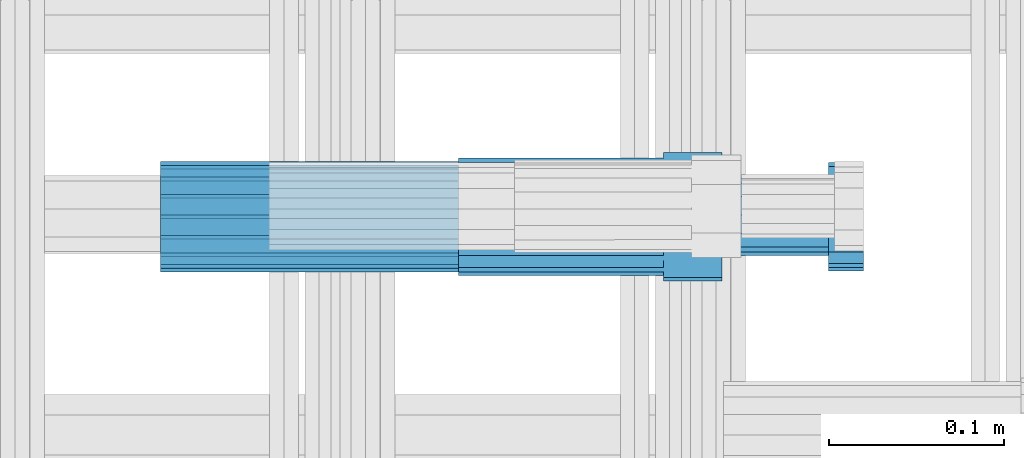
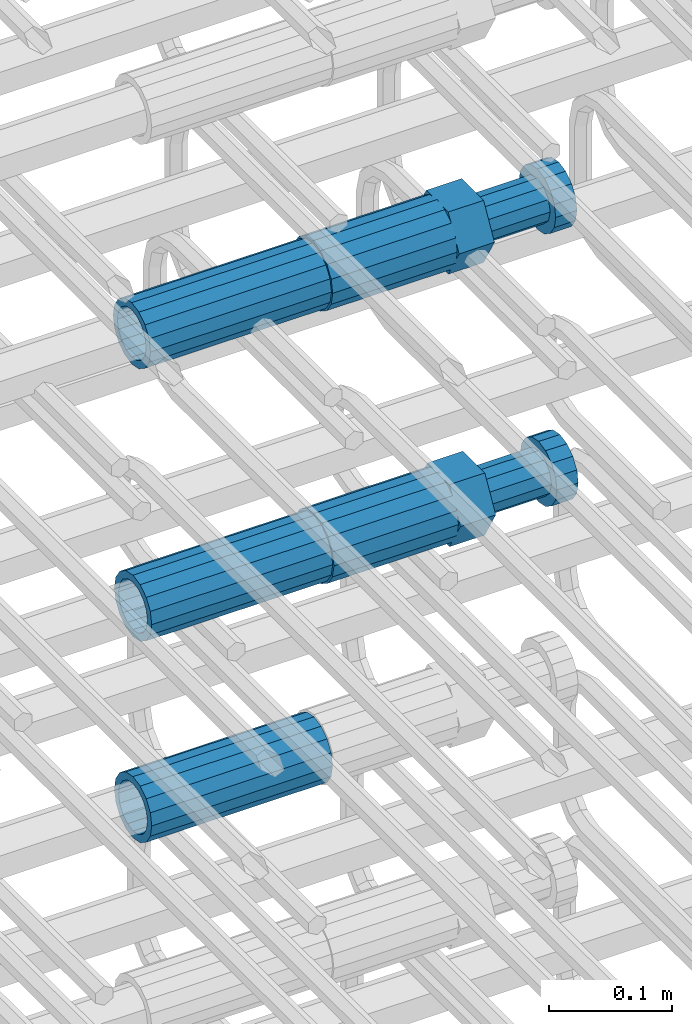
# One storey, part 47 of 177: 5 beams.
"""IFC2X3 building model written with IfcOpenShell, lengths in millimetres."""

from ifc_helpers import new_model, si_unit, frame, origin_with_axes, place, context, subcontext, project, spatial, faceted_brep, material, type_object, element, save


model = new_model("IFC2X3")

# Units and contexts
model_context_1 = context("Model", 3, precision=1e-05, world=origin_with_axes())
model_context_2 = context("Model", 3, precision=1e-05, world=origin_with_axes())
body_context = subcontext(model_context_2, "Body", "Model", "MODEL_VIEW")
ifc_project = project(units=[si_unit("LENGTHUNIT", "METRE", prefix="MILLI"), si_unit("AREAUNIT", "SQUARE_METRE"), si_unit("VOLUMEUNIT", "CUBIC_METRE"), si_unit("MASSUNIT", "GRAM", prefix="KILO"), si_unit("TIMEUNIT", "SECOND"), si_unit("PLANEANGLEUNIT", "RADIAN"), si_unit("SOLIDANGLEUNIT", "STERADIAN"), si_unit("THERMODYNAMICTEMPERATUREUNIT", "DEGREE_CELSIUS"), si_unit("LUMINOUSINTENSITYUNIT", "LUMEN")], contexts=[model_context_1])

# Site, building, storey
site_placement = place(None, origin_with_axes())
site = spatial("IfcSite", under=ifc_project, at=site_placement, CompositionType="ELEMENT")
building_placement = place(site_placement, origin_with_axes())
building = spatial("IfcBuilding", under=site, at=building_placement, Name="Undefined", CompositionType="ELEMENT")
storey_placement = place(building_placement, origin_with_axes())
storey = spatial("IfcBuildingStorey", under=building, at=storey_placement, Name="Undefined", CompositionType="ELEMENT", Elevation=0.0)

# Beams
ifc_material = material(Name="STEEL/S275")
beam_type_1 = type_object("IfcBeamType", PredefinedType="NOTDEFINED")
beam_1_placement = place(storey_placement, frame((2030819.00847313, 6206284.98588033, 21025.9891664316), z_axis=(0.0, 0.0, -1.0), x_axis=(1.0, 0.0, 0.0)))
element("IfcBeam", 1, at=beam_1_placement, inside=storey, type_object=beam_type_1, material=ifc_material, Name="AG40N", context=body_context, shape_type="Brep", body=[
    faceted_brep([(0.0, -23.5000000001164, -9.31322574615479e-10), (0.0, -21.7111690140155, 8.99306066054851), (170.0, -21.7111690140155, 8.99306066054851), (170.0, -23.5, 0.0), (0.0, -16.6170093578839, 16.6170093575493), (170.0, -16.6170093578839, 16.6170093575493), (0.0, -8.99306066057943, 21.7111690137535), (170.0, -8.99306066057943, 21.7111690137535), (0.0, 1.16415321826935e-10, 23.5), (170.0, 0.0, 23.5), (0.0, 8.99306066057943, 21.7111690137535), (170.0, 8.99306066057943, 21.7111690137535), (0.0, 16.6170093578839, 16.6170093575493), (170.0, 16.6170093578839, 16.6170093575493), (0.0, 21.7111690140155, 8.99306066054851), (170.0, 21.7111690140155, 8.99306066054851), (0.0, 23.5000000001164, -9.31322574615479e-10), (170.0, 23.5, 0.0), (0.0, 21.7111690140155, -8.99306066054851), (170.0, 21.7111690140155, -8.99306066054851), (0.0, 16.6170093578839, -16.6170093575493), (170.0, 16.6170093578839, -16.6170093575493), (0.0, 8.99306066057943, -21.7111690137535), (170.0, 8.99306066057943, -21.7111690137535), (0.0, 1.16415321826935e-10, -23.5000000009313), (170.0, 0.0, -23.5), (0.0, -8.99306066057943, -21.7111690137535), (170.0, -8.99306066057943, -21.7111690137535), (0.0, -16.6170093578839, -16.6170093575493), (170.0, -16.6170093578839, -16.6170093575493), (0.0, -21.7111690140155, -8.99306066054851), (170.0, -21.7111690140155, -8.99306066054851), (0.0, -30.5, 0.0), (0.0, -28.1783257415937, -11.6718446873128), (170.0, -28.1783257415937, -11.6718446873128), (170.0, -30.5, 0.0), (0.0, -21.5667568261888, -21.5667568258941), (170.0, -21.5667568261888, -21.5667568258941), (0.0, -11.6718446871346, -28.1783257415518), (170.0, -11.6718446871346, -28.1783257415518), (0.0, 0.0, -30.5), (170.0, 0.0, -30.5), (0.0, 11.6718446871346, -28.1783257415518), (170.0, 11.6718446871346, -28.1783257415518), (0.0, 21.5667568261888, -21.5667568258941), (170.0, 21.5667568261888, -21.5667568258941), (0.0, 28.1783257415937, -11.6718446873128), (170.0, 28.1783257415937, -11.6718446873128), (0.0, 30.5, 0.0), (170.0, 30.5, 0.0), (0.0, 28.1783257415937, 11.6718446873128), (170.0, 28.1783257415937, 11.6718446873128), (0.0, 21.5667568261888, 21.5667568258941), (170.0, 21.5667568261888, 21.5667568258941), (0.0, 11.6718446871346, 28.1783257415518), (170.0, 11.6718446871346, 28.1783257415518), (0.0, 0.0, 30.5), (170.0, 0.0, 30.5), (0.0, -11.6718446871346, 28.1783257415518), (170.0, -11.6718446871346, 28.1783257415518), (0.0, -21.5667568261888, 21.5667568258941), (170.0, -21.5667568261888, 21.5667568258941), (0.0, -28.1783257415937, 11.6718446873128), (170.0, -28.1783257415937, 11.6718446873128)], [[[0, 1, 2, 3]], [[1, 4, 5, 2]], [[4, 6, 7, 5]], [[6, 8, 9, 7]], [[8, 10, 11, 9]], [[10, 12, 13, 11]], [[12, 14, 15, 13]], [[14, 16, 17, 15]], [[16, 18, 19, 17]], [[18, 20, 21, 19]], [[20, 22, 23, 21]], [[22, 24, 25, 23]], [[24, 26, 27, 25]], [[26, 28, 29, 27]], [[28, 30, 31, 29]], [[30, 0, 3, 31]], [[32, 33, 34, 35]], [[33, 36, 37, 34]], [[36, 38, 39, 37]], [[38, 40, 41, 39]], [[40, 42, 43, 41]], [[42, 44, 45, 43]], [[44, 46, 47, 45]], [[46, 48, 49, 47]], [[48, 50, 51, 49]], [[50, 52, 53, 51]], [[52, 54, 55, 53]], [[54, 56, 57, 55]], [[56, 58, 59, 57]], [[58, 60, 61, 59]], [[60, 62, 63, 61]], [[62, 32, 35, 63]], [[37, 39, 41, 43, 45, 47, 49, 51, 53, 55, 57, 59, 61, 63, 35, 34], [5, 7, 9, 11, 13, 15, 17, 19, 21, 23, 25, 27, 29, 31, 3, 2]], [[62, 60, 58, 56, 54, 52, 50, 48, 46, 44, 42, 40, 38, 36, 33, 32], [30, 28, 26, 24, 22, 20, 18, 16, 14, 12, 10, 8, 6, 4, 1, 0]]]),
])
beam_2_placement = place(storey_placement, frame((2030819.00847313, 6206282.98588033, 20756.4868004557), z_axis=(0.0, 0.0, -1.0), x_axis=(1.0, 0.0, 0.0)))
element("IfcBeam", 2, at=beam_2_placement, inside=storey, type_object=beam_type_1, material=ifc_material, Name="AG40N", context=body_context, shape_type="Brep", body=[
    faceted_brep([(0.0, -23.5000000001164, -9.31322574615479e-10), (0.0, -21.7111690140155, 8.99306066054851), (170.0, -21.7111690140155, 8.99306066054851), (170.0, -23.5, 0.0), (0.0, -16.6170093578839, 16.6170093575493), (170.0, -16.6170093578839, 16.6170093575493), (0.0, -8.99306066057943, 21.7111690137535), (170.0, -8.99306066057943, 21.7111690137535), (0.0, 1.16415321826935e-10, 23.5), (170.0, 0.0, 23.5), (0.0, 8.99306066057943, 21.7111690137535), (170.0, 8.99306066057943, 21.7111690137535), (0.0, 16.6170093578839, 16.6170093575493), (170.0, 16.6170093578839, 16.6170093575493), (0.0, 21.7111690140155, 8.99306066054851), (170.0, 21.7111690140155, 8.99306066054851), (0.0, 23.5000000001164, -9.31322574615479e-10), (170.0, 23.5, 0.0), (0.0, 21.7111690140155, -8.99306066054851), (170.0, 21.7111690140155, -8.99306066054851), (0.0, 16.6170093578839, -16.6170093575493), (170.0, 16.6170093578839, -16.6170093575493), (0.0, 8.99306066057943, -21.7111690137535), (170.0, 8.99306066057943, -21.7111690137535), (0.0, 1.16415321826935e-10, -23.5000000009313), (170.0, 0.0, -23.5), (0.0, -8.99306066057943, -21.7111690137535), (170.0, -8.99306066057943, -21.7111690137535), (0.0, -16.6170093578839, -16.6170093575493), (170.0, -16.6170093578839, -16.6170093575493), (0.0, -21.7111690140155, -8.99306066054851), (170.0, -21.7111690140155, -8.99306066054851), (0.0, -30.5, 0.0), (0.0, -28.1783257415937, -11.6718446873128), (170.0, -28.1783257415937, -11.6718446873128), (170.0, -30.5, 0.0), (0.0, -21.5667568261888, -21.5667568258941), (170.0, -21.5667568261888, -21.5667568258941), (0.0, -11.6718446871346, -28.1783257415518), (170.0, -11.6718446871346, -28.1783257415518), (0.0, 0.0, -30.5), (170.0, 0.0, -30.5), (0.0, 11.6718446871346, -28.1783257415518), (170.0, 11.6718446871346, -28.1783257415518), (0.0, 21.5667568261888, -21.5667568258941), (170.0, 21.5667568261888, -21.5667568258941), (0.0, 28.1783257415937, -11.6718446873128), (170.0, 28.1783257415937, -11.6718446873128), (0.0, 30.5, 0.0), (170.0, 30.5, 0.0), (0.0, 28.1783257415937, 11.6718446873128), (170.0, 28.1783257415937, 11.6718446873128), (0.0, 21.5667568261888, 21.5667568258941), (170.0, 21.5667568261888, 21.5667568258941), (0.0, 11.6718446871346, 28.1783257415518), (170.0, 11.6718446871346, 28.1783257415518), (0.0, 0.0, 30.5), (170.0, 0.0, 30.5), (0.0, -11.6718446871346, 28.1783257415518), (170.0, -11.6718446871346, 28.1783257415518), (0.0, -21.5667568261888, 21.5667568258941), (170.0, -21.5667568261888, 21.5667568258941), (0.0, -28.1783257415937, 11.6718446873128), (170.0, -28.1783257415937, 11.6718446873128)], [[[0, 1, 2, 3]], [[1, 4, 5, 2]], [[4, 6, 7, 5]], [[6, 8, 9, 7]], [[8, 10, 11, 9]], [[10, 12, 13, 11]], [[12, 14, 15, 13]], [[14, 16, 17, 15]], [[16, 18, 19, 17]], [[18, 20, 21, 19]], [[20, 22, 23, 21]], [[22, 24, 25, 23]], [[24, 26, 27, 25]], [[26, 28, 29, 27]], [[28, 30, 31, 29]], [[30, 0, 3, 31]], [[32, 33, 34, 35]], [[33, 36, 37, 34]], [[36, 38, 39, 37]], [[38, 40, 41, 39]], [[40, 42, 43, 41]], [[42, 44, 45, 43]], [[44, 46, 47, 45]], [[46, 48, 49, 47]], [[48, 50, 51, 49]], [[50, 52, 53, 51]], [[52, 54, 55, 53]], [[54, 56, 57, 55]], [[56, 58, 59, 57]], [[58, 60, 61, 59]], [[60, 62, 63, 61]], [[62, 32, 35, 63]], [[37, 39, 41, 43, 45, 47, 49, 51, 53, 55, 57, 59, 61, 63, 35, 34], [5, 7, 9, 11, 13, 15, 17, 19, 21, 23, 25, 27, 29, 31, 3, 2]], [[62, 60, 58, 56, 54, 52, 50, 48, 46, 44, 42, 40, 38, 36, 33, 32], [30, 28, 26, 24, 22, 20, 18, 16, 14, 12, 10, 8, 6, 4, 1, 0]]]),
])
beam_3_placement = place(storey_placement, frame((2030819.00847313, 6206282.98588033, 20556.4868004557), z_axis=(0.0, 0.0, -1.0), x_axis=(1.0, 0.0, 0.0)))
element("IfcBeam", 3, at=beam_3_placement, inside=storey, type_object=beam_type_1, material=ifc_material, Name="AG40N", context=body_context, shape_type="Brep", body=[
    faceted_brep([(0.0, -23.5000000001164, -9.31322574615479e-10), (0.0, -21.7111690140155, 8.99306066054851), (170.0, -21.7111690140155, 8.99306066054851), (170.0, -23.5, 0.0), (0.0, -16.6170093578839, 16.6170093575493), (170.0, -16.6170093578839, 16.6170093575493), (0.0, -8.99306066057943, 21.7111690137535), (170.0, -8.99306066057943, 21.7111690137535), (0.0, 1.16415321826935e-10, 23.5), (170.0, 0.0, 23.5), (0.0, 8.99306066057943, 21.7111690137535), (170.0, 8.99306066057943, 21.7111690137535), (0.0, 16.6170093578839, 16.6170093575493), (170.0, 16.6170093578839, 16.6170093575493), (0.0, 21.7111690140155, 8.99306066054851), (170.0, 21.7111690140155, 8.99306066054851), (0.0, 23.5000000001164, -9.31322574615479e-10), (170.0, 23.5, 0.0), (0.0, 21.7111690140155, -8.99306066054851), (170.0, 21.7111690140155, -8.99306066054851), (0.0, 16.6170093578839, -16.6170093575493), (170.0, 16.6170093578839, -16.6170093575493), (0.0, 8.99306066057943, -21.7111690137535), (170.0, 8.99306066057943, -21.7111690137535), (0.0, 1.16415321826935e-10, -23.5000000009313), (170.0, 0.0, -23.5), (0.0, -8.99306066057943, -21.7111690137535), (170.0, -8.99306066057943, -21.7111690137535), (0.0, -16.6170093578839, -16.6170093575493), (170.0, -16.6170093578839, -16.6170093575493), (0.0, -21.7111690140155, -8.99306066054851), (170.0, -21.7111690140155, -8.99306066054851), (0.0, -30.5, 0.0), (0.0, -28.1783257415937, -11.6718446873128), (170.0, -28.1783257415937, -11.6718446873128), (170.0, -30.5, 0.0), (0.0, -21.5667568261888, -21.5667568258941), (170.0, -21.5667568261888, -21.5667568258941), (0.0, -11.6718446871346, -28.1783257415518), (170.0, -11.6718446871346, -28.1783257415518), (0.0, 0.0, -30.5), (170.0, 0.0, -30.5), (0.0, 11.6718446871346, -28.1783257415518), (170.0, 11.6718446871346, -28.1783257415518), (0.0, 21.5667568261888, -21.5667568258941), (170.0, 21.5667568261888, -21.5667568258941), (0.0, 28.1783257415937, -11.6718446873128), (170.0, 28.1783257415937, -11.6718446873128), (0.0, 30.5, 0.0), (170.0, 30.5, 0.0), (0.0, 28.1783257415937, 11.6718446873128), (170.0, 28.1783257415937, 11.6718446873128), (0.0, 21.5667568261888, 21.5667568258941), (170.0, 21.5667568261888, 21.5667568258941), (0.0, 11.6718446871346, 28.1783257415518), (170.0, 11.6718446871346, 28.1783257415518), (0.0, 0.0, 30.5), (170.0, 0.0, 30.5), (0.0, -11.6718446871346, 28.1783257415518), (170.0, -11.6718446871346, 28.1783257415518), (0.0, -21.5667568261888, 21.5667568258941), (170.0, -21.5667568261888, 21.5667568258941), (0.0, -28.1783257415937, 11.6718446873128), (170.0, -28.1783257415937, 11.6718446873128)], [[[0, 1, 2, 3]], [[1, 4, 5, 2]], [[4, 6, 7, 5]], [[6, 8, 9, 7]], [[8, 10, 11, 9]], [[10, 12, 13, 11]], [[12, 14, 15, 13]], [[14, 16, 17, 15]], [[16, 18, 19, 17]], [[18, 20, 21, 19]], [[20, 22, 23, 21]], [[22, 24, 25, 23]], [[24, 26, 27, 25]], [[26, 28, 29, 27]], [[28, 30, 31, 29]], [[30, 0, 3, 31]], [[32, 33, 34, 35]], [[33, 36, 37, 34]], [[36, 38, 39, 37]], [[38, 40, 41, 39]], [[40, 42, 43, 41]], [[42, 44, 45, 43]], [[44, 46, 47, 45]], [[46, 48, 49, 47]], [[48, 50, 51, 49]], [[50, 52, 53, 51]], [[52, 54, 55, 53]], [[54, 56, 57, 55]], [[56, 58, 59, 57]], [[58, 60, 61, 59]], [[60, 62, 63, 61]], [[62, 32, 35, 63]], [[37, 39, 41, 43, 45, 47, 49, 51, 53, 55, 57, 59, 61, 63, 35, 34], [5, 7, 9, 11, 13, 15, 17, 19, 21, 23, 25, 27, 29, 31, 3, 2]], [[62, 60, 58, 56, 54, 52, 50, 48, 46, 44, 42, 40, 38, 36, 33, 32], [30, 28, 26, 24, 22, 20, 18, 16, 14, 12, 10, 8, 6, 4, 1, 0]]]),
])
beam_type_2 = type_object("IfcBeamType", Name="ROD65", PredefinedType="NOTDEFINED")
beam_4_placement = place(storey_placement, frame((2030989.00847313, 6206284.98588033, 21025.9891664316), z_axis=(0.0, 0.0, -1.0), x_axis=(1.0, 0.0, 0.0)))
element("IfcBeam", 4, at=beam_4_placement, inside=storey, type_object=beam_type_2, material=ifc_material, Name="AGB40", ObjectType="ROD65", context=body_context, shape_type="Brep", body=[
    faceted_brep([(117.0, 8.17543110251427, 30.873805644922), (117.0, 17.8250000001863, 30.873805644922), (117.0, 22.0056958701462, 23.6326279877685), (117.0, 12.4372115517035, 30.0260848065373), (117.0, -17.8250000001863, 30.873805644922), (150.200000000186, -17.8250000001863, 30.873805644922), (150.200000000186, 17.8250000001863, 30.873805644922), (117.0, -8.17543110251427, 30.873805644922), (117.0, -12.4372115517035, 30.0260848065373), (117.0, -22.0056958701462, 23.6326279877685), (117.0, -35.6500000003725, 0.0), (150.200000000186, -35.6500000003725, 0.0), (117.0, -30.8443150008097, 8.32369058486074), (117.0, -32.5, 0.0), (117.0, -30.8443150008097, -8.32369058462791), (117.0, -17.8250000001863, -30.873805644922), (150.200000000186, -17.8250000001863, -30.873805644922), (117.0, -22.0056958701462, -23.6326279877685), (117.0, -12.4372115517035, -30.0260848065373), (117.0, -8.17543110251427, -30.873805644922), (117.0, 17.8250000001863, -30.873805644922), (150.200000000186, 17.8250000001863, -30.873805644922), (117.0, 8.17543110251427, -30.873805644922), (117.0, 22.0056958701462, -23.6326279877685), (117.0, 12.4372115517035, -30.0260848065373), (117.0, 35.6500000003725, 0.0), (150.200000000186, 35.6500000003725, 0.0), (117.0, 30.8443150008097, -8.32369058486074), (117.0, 30.8443150008097, 8.32369058462791), (117.0, 32.5, 0.0), (0.0, -22.9809703892097, 22.9809703885621), (0.0, -30.0260848058388, 12.4372115518636), (117.0, -30.0260848067701, 12.4372115519363), (117.0, -22.9809703882784, 22.9809703885112), (-2.3283064365387e-10, 22.9809703892097, -22.9809703885639), (-4.65661287307739e-10, 30.0260848077014, -12.4372115518672), (117.0, 30.0260848067701, -12.4372115519363), (117.0, 22.9809703882784, -22.9809703885112), (-2.3283064365387e-10, -30.0260848067701, -12.4372115518672), (-2.3283064365387e-10, -22.9809703892097, -22.9809703885621), (117.0, -22.9809703882784, -22.9809703885112), (117.0, -30.0260848067701, -12.4372115519363), (-2.3283064365387e-10, -12.4372115507722, 30.0260848066137), (-2.3283064365387e-10, 9.31322574615479e-10, 32.4999999999982), (-2.3283064365387e-10, 12.4372115526348, 30.0260848066137), (0.0, 22.9809703892097, 22.9809703885621), (-2.3283064365387e-10, 30.0260848077014, 12.4372115518636), (-2.3283064365387e-10, 32.5, 0.0), (-2.3283064365387e-10, 12.4372115526348, -30.0260848066173), (-2.3283064365387e-10, 9.31322574615479e-10, -32.5), (-2.3283064365387e-10, -12.4372115517035, -30.0260848066173), (-4.65661287307739e-10, -32.4999999990687, -1.81898940354586e-12), (117.0, 22.9809703882784, 22.9809703885112), (117.0, 30.0260848067701, 12.4372115519363), (117.0, 0.0, -32.5), (117.0, 0.0, 32.5), (150.200000000186, 10.5, -18.1865334794857), (150.200000000186, 0.0, -21.0), (150.200000000186, -10.5, -18.1865334794857), (150.200000000186, -18.18653347902, -10.5), (150.200000000186, -21.0, 0.0), (150.200000000186, -18.18653347902, 10.5), (150.200000000186, -10.5, 18.1865334794857), (150.200000000186, 0.0, 21.0), (150.200000000186, 10.5, 18.1865334794857), (150.200000000186, 18.18653347902, 10.5), (150.200000000186, 21.0, 0.0), (150.200000000186, 18.18653347902, -10.5), (210.980000000447, -18.18653347902, 10.5), (210.980000000447, -21.0, 0.0), (210.980000000447, -10.5, 18.1865334794857), (210.980000000447, 0.0, 21.0), (210.980000000447, 10.5, 18.1865334794857), (210.980000000447, 18.18653347902, 10.5), (210.980000000447, 21.0, 0.0), (210.980000000447, 18.18653347902, -10.5), (210.980000000447, 10.5, -18.1865334794857), (210.980000000447, 0.0, -21.0), (210.980000000447, -10.5, -18.1865334794857), (210.980000000447, -18.18653347902, -10.5), (211.001368442696, -27.7269937992096, -11.491116326768), (211.003082550167, -21.2238094303757, -21.223815418547), (231.002518367059, -21.2131944671273, -21.2132004550658), (231.000804259587, -27.7163788359612, -11.4805013632867), (211.001368440451, -11.4911085031927, -27.7269970395137), (231.000804257343, -11.4804935399443, -27.7163820760325), (210.996487071217, -0.0106065049767494, -30.0106107392348), (230.995922888109, 8.45827162265778e-06, -29.9999957757536), (210.989181586672, 11.46989420522, -27.7269970329944), (230.988617403564, 11.4805091684684, -27.7163820695132), (210.980564180623, 21.2025914648548, -21.2238154064398), (230.979999997515, 21.2132064281031, -21.2132004429586), (210.971946775022, 27.7057703435421, -11.4911163107026), (230.971382591913, 27.7163853067905, -11.4805013472214), (210.96464129175, 29.9893808094785, -0.0106149562634528), (230.964077108642, 29.9999957727268, 7.21774995326996e-09), (210.959759924415, 27.7057638689876, 11.4698863970116), (230.959195741307, 27.7163788322359, 11.4805013604928), (210.958045816944, 21.2025795001537, 21.2025854887906), (230.957481633835, 21.213194463402, 21.2132004522718), (210.95975992666, 11.4698785729706, 27.7057671097573), (230.959195743551, 11.480493536219, 27.7163820732385), (210.964641295894, -0.010623425245285, 29.9893808094785), (230.964077112785, -8.46199691295624e-06, 29.9999957729597), (210.971946780439, -11.4911241354421, 27.705767103238), (230.97138259733, -11.4805091721937, 27.7163820667192), (210.980564186488, -21.2238213950768, 21.2025854766835), (230.980000003379, -21.2132064318284, 21.2132004401647), (210.989181592089, -27.7270002737641, 11.4698863809463), (230.988617408981, -27.7163853105158, 11.4805013444275), (210.996487075361, -30.0106107397005, -0.0106149734929204), (230.995922892253, -29.9999957764521, -1.00117176771164e-08)], [[[0, 1, 2, 3]], [[4, 5, 6, 1, 0, 7]], [[4, 7, 8, 9]], [[10, 11, 5, 4, 9, 12]], [[10, 12, 13, 14]], [[15, 16, 11, 10, 14, 17]], [[15, 17, 18, 19]], [[20, 21, 16, 15, 19, 22]], [[23, 20, 22, 24]], [[25, 26, 21, 20, 23, 27]], [[28, 25, 27, 29]], [[30, 31, 32, 33]], [[34, 35, 36, 37]], [[38, 39, 40, 41]], [[31, 30, 42, 43, 44, 45, 46, 47, 35, 34, 48, 49, 50, 39, 38, 51]], [[46, 45, 52, 53]], [[29, 47, 46, 53, 28]], [[27, 36, 35, 47, 29]], [[23, 37, 36, 27]], [[24, 48, 34, 37, 23]], [[22, 54, 49, 48, 24]], [[19, 54, 22]], [[18, 50, 49, 54, 19]], [[17, 40, 39, 50, 18]], [[14, 41, 40, 17]], [[13, 51, 38, 41, 14]], [[12, 32, 31, 51, 13]], [[9, 33, 32, 12]], [[8, 42, 30, 33, 9]], [[7, 55, 43, 42, 8]], [[0, 55, 7]], [[3, 44, 43, 55, 0]], [[2, 52, 45, 44, 3]], [[28, 53, 52, 2]], [[1, 6, 26, 25, 28, 2]], [[5, 11, 16, 21, 26, 6], [56, 57, 58, 59, 60, 61, 62, 63, 64, 65, 66, 67]], [[68, 61, 60, 69]], [[70, 62, 61, 68]], [[71, 63, 62, 70]], [[72, 64, 63, 71]], [[73, 65, 64, 72]], [[74, 66, 65, 73]], [[75, 67, 66, 74]], [[76, 56, 67, 75]], [[77, 57, 56, 76]], [[78, 58, 57, 77]], [[79, 59, 58, 78]], [[69, 60, 59, 79]], [[80, 81, 82, 83]], [[81, 84, 85, 82]], [[84, 86, 87, 85]], [[86, 88, 89, 87]], [[88, 90, 91, 89]], [[90, 92, 93, 91]], [[92, 94, 95, 93]], [[94, 96, 97, 95]], [[96, 98, 99, 97]], [[98, 100, 101, 99]], [[100, 102, 103, 101]], [[102, 104, 105, 103]], [[104, 106, 107, 105]], [[106, 108, 109, 107]], [[108, 110, 111, 109]], [[82, 85, 87, 89, 91, 93, 95, 97, 99, 101, 103, 105, 107, 109, 111, 83]], [[110, 80, 83, 111]], [[108, 106, 104, 102, 100, 98, 96, 94, 92, 90, 88, 86, 84, 81, 80, 110], [75, 74, 73, 72, 71, 70, 68, 69, 79, 78, 77, 76]]]),
])
beam_5_placement = place(storey_placement, frame((2030989.00847313, 6206282.98588033, 20756.4868004557), z_axis=(0.0, 0.0, -1.0), x_axis=(1.0, 0.0, 0.0)))
element("IfcBeam", 5, at=beam_5_placement, inside=storey, type_object=beam_type_2, material=ifc_material, Name="AGB40", ObjectType="ROD65", context=body_context, shape_type="Brep", body=[
    faceted_brep([(117.0, 8.17543110251427, 30.873805644922), (117.0, 17.8250000001863, 30.873805644922), (117.0, 22.0056958701462, 23.6326279877685), (117.0, 12.4372115517035, 30.0260848065373), (117.0, -17.8250000001863, 30.873805644922), (150.200000000186, -17.8250000001863, 30.873805644922), (150.200000000186, 17.8250000001863, 30.873805644922), (117.0, -8.17543110251427, 30.873805644922), (117.0, -12.4372115517035, 30.0260848065373), (117.0, -22.0056958701462, 23.6326279877685), (117.0, -35.6500000003725, 0.0), (150.200000000186, -35.6500000003725, 0.0), (117.0, -30.8443150008097, 8.32369058486074), (117.0, -32.5, 0.0), (117.0, -30.8443150008097, -8.32369058462791), (117.0, -17.8250000001863, -30.873805644922), (150.200000000186, -17.8250000001863, -30.873805644922), (117.0, -22.0056958701462, -23.6326279877685), (117.0, -12.4372115517035, -30.0260848065373), (117.0, -8.17543110251427, -30.873805644922), (117.0, 17.8250000001863, -30.873805644922), (150.200000000186, 17.8250000001863, -30.873805644922), (117.0, 8.17543110251427, -30.873805644922), (117.0, 22.0056958701462, -23.6326279877685), (117.0, 12.4372115517035, -30.0260848065373), (117.0, 35.6500000003725, 0.0), (150.200000000186, 35.6500000003725, 0.0), (117.0, 30.8443150008097, -8.32369058486074), (117.0, 30.8443150008097, 8.32369058462791), (117.0, 32.5, 0.0), (0.0, -22.9809703892097, 22.9809703885621), (0.0, -30.0260848058388, 12.4372115518636), (117.0, -30.0260848067701, 12.4372115519363), (117.0, -22.9809703882784, 22.9809703885112), (-2.3283064365387e-10, 22.9809703892097, -22.9809703885639), (-4.65661287307739e-10, 30.0260848077014, -12.4372115518672), (117.0, 30.0260848067701, -12.4372115519363), (117.0, 22.9809703882784, -22.9809703885112), (-2.3283064365387e-10, -30.0260848067701, -12.4372115518672), (-2.3283064365387e-10, -22.9809703892097, -22.9809703885621), (117.0, -22.9809703882784, -22.9809703885112), (117.0, -30.0260848067701, -12.4372115519363), (-2.3283064365387e-10, -12.4372115507722, 30.0260848066137), (-2.3283064365387e-10, 9.31322574615479e-10, 32.4999999999982), (-2.3283064365387e-10, 12.4372115526348, 30.0260848066137), (0.0, 22.9809703892097, 22.9809703885621), (-2.3283064365387e-10, 30.0260848077014, 12.4372115518636), (-2.3283064365387e-10, 32.5, 0.0), (-2.3283064365387e-10, 12.4372115526348, -30.0260848066173), (-2.3283064365387e-10, 9.31322574615479e-10, -32.5), (-2.3283064365387e-10, -12.4372115517035, -30.0260848066173), (-4.65661287307739e-10, -32.4999999990687, -1.81898940354586e-12), (117.0, 22.9809703882784, 22.9809703885112), (117.0, 30.0260848067701, 12.4372115519363), (117.0, 0.0, -32.5), (117.0, 0.0, 32.5), (150.200000000186, 10.5, -18.1865334794857), (150.200000000186, 0.0, -21.0), (150.200000000186, -10.5, -18.1865334794857), (150.200000000186, -18.18653347902, -10.5), (150.200000000186, -21.0, 0.0), (150.200000000186, -18.18653347902, 10.5), (150.200000000186, -10.5, 18.1865334794857), (150.200000000186, 0.0, 21.0), (150.200000000186, 10.5, 18.1865334794857), (150.200000000186, 18.18653347902, 10.5), (150.200000000186, 21.0, 0.0), (150.200000000186, 18.18653347902, -10.5), (210.980000000447, -18.18653347902, 10.5), (210.980000000447, -21.0, 0.0), (210.980000000447, -10.5, 18.1865334794857), (210.980000000447, 0.0, 21.0), (210.980000000447, 10.5, 18.1865334794857), (210.980000000447, 18.18653347902, 10.5), (210.980000000447, 21.0, 0.0), (210.980000000447, 18.18653347902, -10.5), (210.980000000447, 10.5, -18.1865334794857), (210.980000000447, 0.0, -21.0), (210.980000000447, -10.5, -18.1865334794857), (210.980000000447, -18.18653347902, -10.5), (211.001368442696, -27.7269937992096, -11.491116326768), (211.003082550167, -21.2238094303757, -21.223815418547), (231.002518367059, -21.2131944671273, -21.2132004550658), (231.000804259587, -27.7163788359612, -11.4805013632867), (211.001368440451, -11.4911085031927, -27.7269970395137), (231.000804257343, -11.4804935399443, -27.7163820760325), (210.996487071217, -0.0106065049767494, -30.0106107392348), (230.995922888109, 8.45827162265778e-06, -29.9999957757536), (210.989181586672, 11.46989420522, -27.7269970329944), (230.988617403564, 11.4805091684684, -27.7163820695132), (210.980564180623, 21.2025914648548, -21.2238154064398), (230.979999997515, 21.2132064281031, -21.2132004429586), (210.971946775022, 27.7057703435421, -11.4911163107026), (230.971382591913, 27.7163853067905, -11.4805013472214), (210.96464129175, 29.9893808094785, -0.0106149562634528), (230.964077108642, 29.9999957727268, 7.21774995326996e-09), (210.959759924415, 27.7057638689876, 11.4698863970116), (230.959195741307, 27.7163788322359, 11.4805013604928), (210.958045816944, 21.2025795001537, 21.2025854887906), (230.957481633835, 21.213194463402, 21.2132004522718), (210.95975992666, 11.4698785729706, 27.7057671097573), (230.959195743551, 11.480493536219, 27.7163820732385), (210.964641295894, -0.010623425245285, 29.9893808094785), (230.964077112785, -8.46199691295624e-06, 29.9999957729597), (210.971946780439, -11.4911241354421, 27.705767103238), (230.97138259733, -11.4805091721937, 27.7163820667192), (210.980564186488, -21.2238213950768, 21.2025854766835), (230.980000003379, -21.2132064318284, 21.2132004401647), (210.989181592089, -27.7270002737641, 11.4698863809463), (230.988617408981, -27.7163853105158, 11.4805013444275), (210.996487075361, -30.0106107397005, -0.0106149734929204), (230.995922892253, -29.9999957764521, -1.00117176771164e-08)], [[[0, 1, 2, 3]], [[4, 5, 6, 1, 0, 7]], [[4, 7, 8, 9]], [[10, 11, 5, 4, 9, 12]], [[10, 12, 13, 14]], [[15, 16, 11, 10, 14, 17]], [[15, 17, 18, 19]], [[20, 21, 16, 15, 19, 22]], [[23, 20, 22, 24]], [[25, 26, 21, 20, 23, 27]], [[28, 25, 27, 29]], [[30, 31, 32, 33]], [[34, 35, 36, 37]], [[38, 39, 40, 41]], [[31, 30, 42, 43, 44, 45, 46, 47, 35, 34, 48, 49, 50, 39, 38, 51]], [[46, 45, 52, 53]], [[29, 47, 46, 53, 28]], [[27, 36, 35, 47, 29]], [[23, 37, 36, 27]], [[24, 48, 34, 37, 23]], [[22, 54, 49, 48, 24]], [[19, 54, 22]], [[18, 50, 49, 54, 19]], [[17, 40, 39, 50, 18]], [[14, 41, 40, 17]], [[13, 51, 38, 41, 14]], [[12, 32, 31, 51, 13]], [[9, 33, 32, 12]], [[8, 42, 30, 33, 9]], [[7, 55, 43, 42, 8]], [[0, 55, 7]], [[3, 44, 43, 55, 0]], [[2, 52, 45, 44, 3]], [[28, 53, 52, 2]], [[1, 6, 26, 25, 28, 2]], [[5, 11, 16, 21, 26, 6], [56, 57, 58, 59, 60, 61, 62, 63, 64, 65, 66, 67]], [[68, 61, 60, 69]], [[70, 62, 61, 68]], [[71, 63, 62, 70]], [[72, 64, 63, 71]], [[73, 65, 64, 72]], [[74, 66, 65, 73]], [[75, 67, 66, 74]], [[76, 56, 67, 75]], [[77, 57, 56, 76]], [[78, 58, 57, 77]], [[79, 59, 58, 78]], [[69, 60, 59, 79]], [[80, 81, 82, 83]], [[81, 84, 85, 82]], [[84, 86, 87, 85]], [[86, 88, 89, 87]], [[88, 90, 91, 89]], [[90, 92, 93, 91]], [[92, 94, 95, 93]], [[94, 96, 97, 95]], [[96, 98, 99, 97]], [[98, 100, 101, 99]], [[100, 102, 103, 101]], [[102, 104, 105, 103]], [[104, 106, 107, 105]], [[106, 108, 109, 107]], [[108, 110, 111, 109]], [[82, 85, 87, 89, 91, 93, 95, 97, 99, 101, 103, 105, 107, 109, 111, 83]], [[110, 80, 83, 111]], [[108, 106, 104, 102, 100, 98, 96, 94, 92, 90, 88, 86, 84, 81, 80, 110], [75, 74, 73, 72, 71, 70, 68, 69, 79, 78, 77, 76]]]),
])

save(model, "model.ifc")
